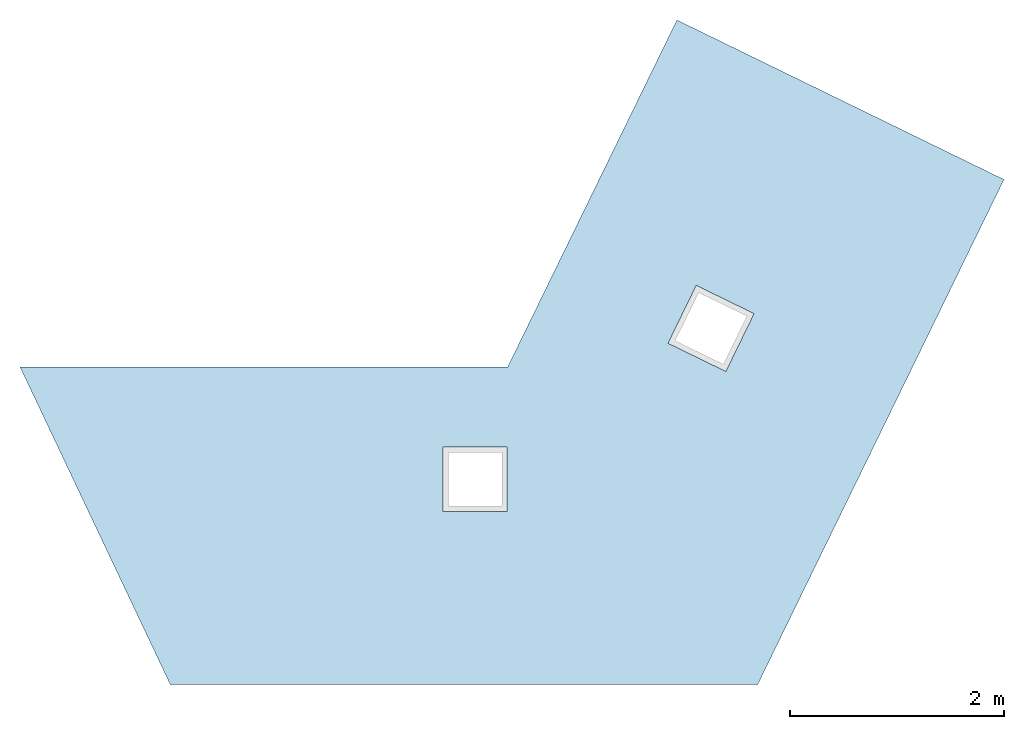
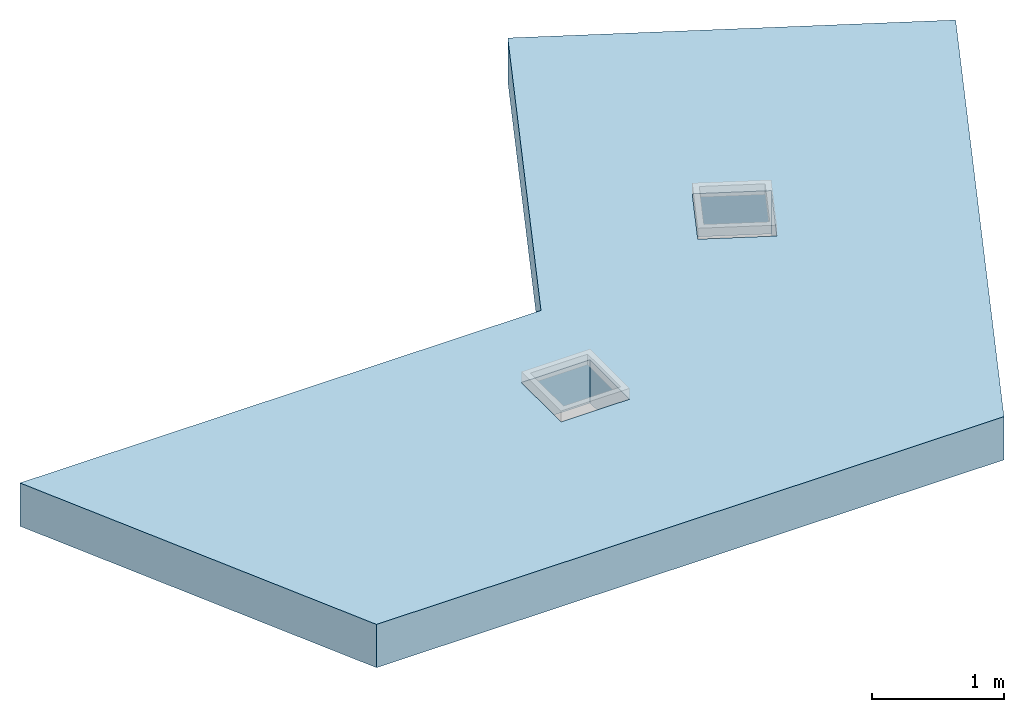
# One storey, part 1 of 2: 1 slab, 2 openings, 1 element without a shape of its own.
"""IFC4 building model written with IfcOpenShell, lengths in metres."""

from ifc_helpers import new_model, entity, si_unit, converted_unit, derived_unit, direction, frame, origin, place, context, subcontext, project, spatial, indexed_curve, outline, extrude, type_object, element, aggregate, save


model = new_model("IFC4")

# Units and contexts
model_context = context("Model", 3, precision=1e-05, world=origin(), true_north=direction((6.12303176911189e-17, 1.0)))
body_context = subcontext(model_context, "Body", "Model", "MODEL_VIEW")
ifc_project = project(units=[si_unit("LENGTHUNIT", "METRE"), si_unit("AREAUNIT", "SQUARE_METRE"), si_unit("VOLUMEUNIT", "CUBIC_METRE"), converted_unit("PLANEANGLEUNIT", "DEGREE", entity("IfcRatioMeasure", 0.0174532925199433), si_unit("PLANEANGLEUNIT", "RADIAN"), dimensions=[0, 0, 0, 0, 0, 0, 0]), si_unit("MASSUNIT", "GRAM", prefix="KILO"), derived_unit("MASSDENSITYUNIT", [(si_unit("MASSUNIT", "GRAM", prefix="KILO"), 1), (si_unit("LENGTHUNIT", "METRE"), -3)]), si_unit("TIMEUNIT", "SECOND"), si_unit("FREQUENCYUNIT", "HERTZ"), si_unit("THERMODYNAMICTEMPERATUREUNIT", "DEGREE_CELSIUS"), derived_unit("THERMALTRANSMITTANCEUNIT", [(si_unit("MASSUNIT", "GRAM", prefix="KILO"), 1), (si_unit("THERMODYNAMICTEMPERATUREUNIT", "KELVIN"), -1), (si_unit("TIMEUNIT", "SECOND"), -3)]), derived_unit("VOLUMETRICFLOWRATEUNIT", [(si_unit("LENGTHUNIT", "METRE"), 3), (si_unit("TIMEUNIT", "SECOND"), -1)]), si_unit("ELECTRICCURRENTUNIT", "AMPERE"), si_unit("ELECTRICVOLTAGEUNIT", "VOLT"), si_unit("POWERUNIT", "WATT"), si_unit("FORCEUNIT", "NEWTON", prefix="KILO"), si_unit("ILLUMINANCEUNIT", "LUX"), si_unit("LUMINOUSFLUXUNIT", "LUMEN"), si_unit("LUMINOUSINTENSITYUNIT", "CANDELA"), derived_unit("USERDEFINED", [(si_unit("MASSUNIT", "GRAM", prefix="KILO"), -1), (si_unit("LENGTHUNIT", "METRE"), -2), (si_unit("TIMEUNIT", "SECOND"), 3), (si_unit("LUMINOUSFLUXUNIT", "LUMEN"), 1)]), derived_unit("LINEARVELOCITYUNIT", [(si_unit("LENGTHUNIT", "METRE"), 1), (si_unit("TIMEUNIT", "SECOND"), -1)]), si_unit("PRESSUREUNIT", "PASCAL"), derived_unit("USERDEFINED", [(si_unit("LENGTHUNIT", "METRE"), -2), (si_unit("MASSUNIT", "GRAM", prefix="KILO"), 1), (si_unit("TIMEUNIT", "SECOND"), -2)])], contexts=[model_context])

# Site, building, storey
site_placement = place(None, origin())
site = spatial("IfcSite", under=ifc_project, at=site_placement, CompositionType="ELEMENT")
building_placement = place(site_placement, origin())
building = spatial("IfcBuilding", under=site, at=building_placement, Name="Revit Advanced Sample", CompositionType="ELEMENT")
storey_placement = place(building_placement, frame((0.0, 0.0, 3.80000000000133)))
storey = spatial("IfcBuildingStorey", under=building, at=storey_placement, Name="E1", CompositionType="ELEMENT", Elevation=3.80000000000133)

# Roof, slab, openings
roof_type = type_object("IfcRoofType", PredefinedType="NOTDEFINED")
roof_placement = place(storey_placement, origin())
roof = element("IfcRoof", 1, at=roof_placement, inside=storey, type_object=roof_type, PredefinedType="NOTDEFINED")
slab_placement = place(storey_placement, origin())
slab = element("IfcSlab", 2, at=slab_placement, PredefinedType="ROOF", context=body_context, shape_type="SweptSolid", body=[
    extrude(outline(indexed_curve([(-2.15077792979021, -4.17828516162214), (1.13196051619294, -4.17828516162214), (3.47886601536876, 0.78187759404353), (0.198250272246556, 4.87986401016125), (-2.45600003811685, 2.75502159484294), (-0.202298835901195, -0.0601928758034377), (-2.15077792979021, -4.17828516162214)], self_intersect=False)), frame((1.14693406461897, -2.80315159929068, 0.0), z_axis=(0.0, 0.0, 1.0), x_axis=(0.42769257940976, -0.903924254303327, 0.0)), (0.0, 0.0, 1.0), 0.4),
])
opening_1_placement = place(storey_placement, origin())
element("IfcOpeningElement", 3, at=opening_1_placement, cuts=slab, ObjectType="Opening", PredefinedType="OPENING", context=body_context, shape_type="SweptSolid", body=[
    extrude(outline(indexed_curve([(-0.3, -0.299999999999998), (0.299999999999999, -0.299999999999998), (0.299999999999999, 0.299999999999998), (-0.3, 0.299999999999998), (-0.3, -0.299999999999998)], self_intersect=False)), frame((0.701761701821962, -3.69603282121672, 0.0), z_axis=(0.0, 0.0, 1.0), x_axis=(0.0, 1.0, 0.0)), (0.0, 0.0, 1.0), 0.4),
])
opening_2_placement = place(storey_placement, origin())
element("IfcOpeningElement", 4, at=opening_2_placement, cuts=slab, ObjectType="Opening", PredefinedType="OPENING", context=body_context, shape_type="SweptSolid", body=[
    extrude(outline(indexed_curve([(-0.3, -0.299999999999998), (0.3, -0.299999999999998), (0.3, 0.299999999999999), (-0.3, 0.299999999999999), (-0.3, -0.299999999999998)], self_intersect=False)), frame((2.90597337612474, -2.28633199499502, 0.0), z_axis=(0.0, 0.0, 1.0), x_axis=(0.438371146789079, 0.898794046299166, 0.0)), (0.0, 0.0, 1.0), 0.4),
])
aggregate(roof, [slab])

save(model, "model.ifc")
